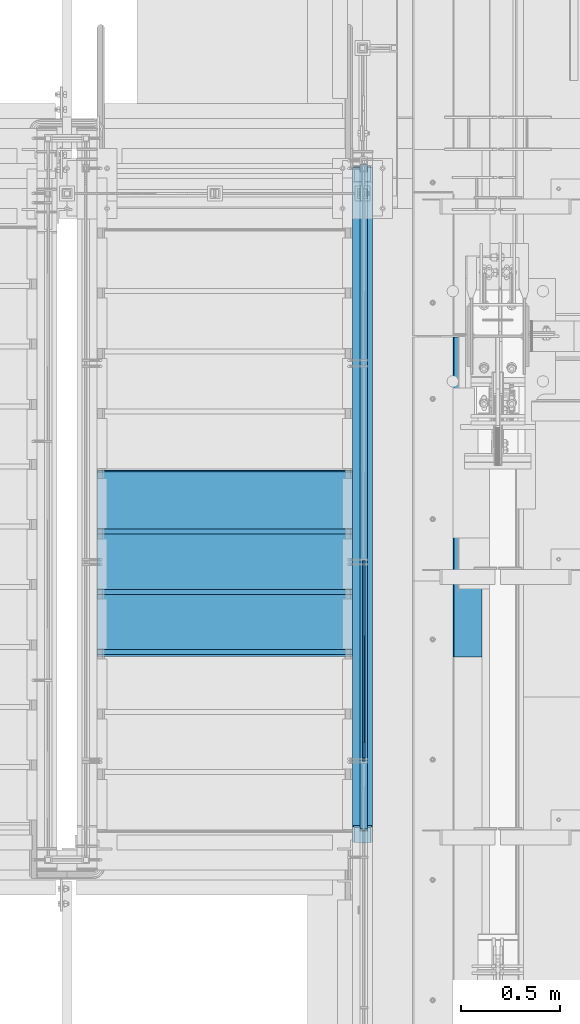
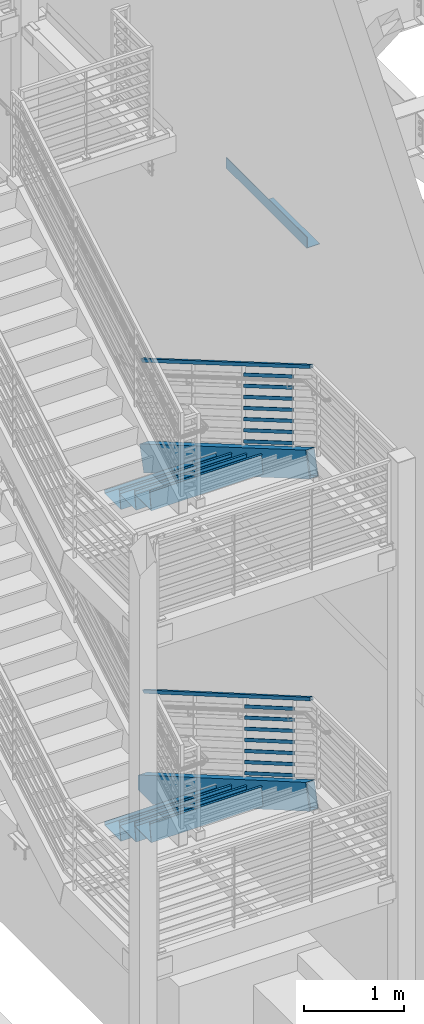
# One storey, part 761 of 1179: 18 members, 7 beams, 5 elements without a shape of their own.
"""IFC2X3 building model written with IfcOpenShell, lengths in millimetres."""

from ifc_helpers import new_model, si_unit, frame, origin_with_axes, place, context, subcontext, project, spatial, faceted_brep, material, type_object, element, aggregate, save


model = new_model("IFC2X3")

# Units and contexts
model_context = context("Model", 3, precision=1e-05, world=origin_with_axes())
body_context = subcontext(model_context, "Body", "Model", "MODEL_VIEW")
ifc_project = project(units=[si_unit("LENGTHUNIT", "METRE", prefix="MILLI"), si_unit("AREAUNIT", "SQUARE_METRE"), si_unit("VOLUMEUNIT", "CUBIC_METRE"), si_unit("MASSUNIT", "GRAM", prefix="KILO"), si_unit("TIMEUNIT", "SECOND"), si_unit("PLANEANGLEUNIT", "RADIAN"), si_unit("SOLIDANGLEUNIT", "STERADIAN"), si_unit("THERMODYNAMICTEMPERATUREUNIT", "DEGREE_CELSIUS"), si_unit("LUMINOUSINTENSITYUNIT", "LUMEN")], contexts=[model_context])

# Site, building, storey
site_placement = place(None, origin_with_axes())
site = spatial("IfcSite", under=ifc_project, at=site_placement, CompositionType="ELEMENT")
building_placement = place(site_placement, origin_with_axes())
building = spatial("IfcBuilding", under=site, at=building_placement, Name="Undefined", CompositionType="ELEMENT")
storey_placement = place(building_placement, origin_with_axes())
storey = spatial("IfcBuildingStorey", under=building, at=storey_placement, Name="Undefined", CompositionType="ELEMENT", Elevation=0.0)

# Assembly, members
assembly_1_placement = place(storey_placement, origin_with_axes())
assembly_1 = element("IfcElementAssembly", 1, at=assembly_1_placement, inside=storey, Name="GUARDRAIL", AssemblyPlace="NOTDEFINED", PredefinedType="RIGID_FRAME")
ifc_material_1 = material(Name="STEEL/A36")
member_type_1 = type_object("IfcMemberType", PredefinedType="NOTDEFINED")
member_1_placement = place(assembly_1_placement, frame((-247.650000724804, 33249.1605808903, 5514.93325604633), z_axis=(0.0, 0.503871025834968, 0.863778900717086), x_axis=(0.0, -0.863778900717086, 0.503871025834967)))
member_1 = element("IfcMember", 2, at=member_1_placement, type_object=member_type_1, material=ifc_material_1, Name="PLATE", context=body_context, shape_type="Brep", body=[
    faceted_brep([(-16.7114354625264, 4.76250000000005, -19.0500000000065), (5.51356370517169, 4.76250000000005, 19.0500000000338), (1164.83261782332, 4.76250000000005, 19.0499999989988), (1142.607617805, 4.76250000000005, -19.0500000010361), (5.51356370517169, -4.76250000000005, 19.0500000000338), (1164.83261782332, -4.76250000000005, 19.0499999989988), (-16.7114354625264, -4.76250000000005, -19.0500000000065), (1142.607617805, -4.76250000000005, -19.0500000010361)], [[[0, 1, 2, 3]], [[1, 4, 5, 2]], [[4, 6, 7, 5]], [[6, 0, 3, 7]], [[5, 7, 3, 2]], [[6, 4, 1, 0]]]),
])
member_2_placement = place(assembly_1_placement, frame((-247.650000724804, 33249.1605808862, 5651.11676564482), z_axis=(0.0, 0.503871025834968, 0.863778900717086), x_axis=(0.0, -0.863778900717086, 0.503871025834967)))
member_2 = element("IfcMember", 3, at=member_2_placement, type_object=member_type_1, material=ifc_material_1, Name="PLATE", context=body_context, shape_type="Brep", body=[
    faceted_brep([(-16.7114354625264, 4.76250000000005, -19.0500000000065), (5.51356370517169, 4.76250000000005, 19.0500000000338), (1164.83261782332, 4.76250000000005, 19.0499999989988), (1142.607617805, 4.76250000000005, -19.0500000010361), (5.51356370517169, -4.76250000000005, 19.0500000000338), (1164.83261782332, -4.76250000000005, 19.0499999989988), (-16.7114354625264, -4.76250000000005, -19.0500000000065), (1142.607617805, -4.76250000000005, -19.0500000010361)], [[[0, 1, 2, 3]], [[1, 4, 5, 2]], [[4, 6, 7, 5]], [[6, 0, 3, 7]], [[5, 7, 3, 2]], [[6, 4, 1, 0]]]),
])
member_3_placement = place(assembly_1_placement, frame((-247.650000724804, 33249.1605808819, 5787.30027524358), z_axis=(0.0, 0.503871025834968, 0.863778900717086), x_axis=(0.0, -0.863778900717086, 0.503871025834967)))
member_3 = element("IfcMember", 4, at=member_3_placement, type_object=member_type_1, material=ifc_material_1, Name="PLATE", context=body_context, shape_type="Brep", body=[
    faceted_brep([(-16.7114354625264, 4.76250000000005, -19.0500000000065), (5.51356370517169, 4.76250000000005, 19.0500000000338), (1164.83261782332, 4.76250000000005, 19.0499999989988), (1142.607617805, 4.76250000000005, -19.0500000010361), (5.51356370517169, -4.76250000000005, 19.0500000000338), (1164.83261782332, -4.76250000000005, 19.0499999989988), (-16.7114354625264, -4.76250000000005, -19.0500000000065), (1142.607617805, -4.76250000000005, -19.0500000010361)], [[[0, 1, 2, 3]], [[1, 4, 5, 2]], [[4, 6, 7, 5]], [[6, 0, 3, 7]], [[5, 7, 3, 2]], [[6, 4, 1, 0]]]),
])
member_4_placement = place(assembly_1_placement, frame((-247.650000724804, 33249.1605808778, 5923.48378484178), z_axis=(0.0, 0.503871025834968, 0.863778900717086), x_axis=(0.0, -0.863778900717086, 0.503871025834967)))
member_4 = element("IfcMember", 5, at=member_4_placement, type_object=member_type_1, material=ifc_material_1, Name="PLATE", context=body_context, shape_type="Brep", body=[
    faceted_brep([(-16.7114354625264, 4.76250000000005, -19.0500000000065), (5.51356370517169, 4.76250000000005, 19.0500000000338), (1164.83261782332, 4.76250000000005, 19.0499999989988), (1142.607617805, 4.76250000000005, -19.0500000010361), (5.51356370517169, -4.76250000000005, 19.0500000000338), (1164.83261782332, -4.76250000000005, 19.0499999989988), (-16.7114354625264, -4.76250000000005, -19.0500000000065), (1142.607617805, -4.76250000000005, -19.0500000010361)], [[[0, 1, 2, 3]], [[1, 4, 5, 2]], [[4, 6, 7, 5]], [[6, 0, 3, 7]], [[5, 7, 3, 2]], [[6, 4, 1, 0]]]),
])
member_5_placement = place(assembly_1_placement, frame((-247.650000724804, 33249.1605808735, 6059.66729443968), z_axis=(0.0, 0.503871025834968, 0.863778900717086), x_axis=(0.0, -0.863778900717086, 0.503871025834967)))
member_5 = element("IfcMember", 6, at=member_5_placement, type_object=member_type_1, material=ifc_material_1, Name="PLATE", context=body_context, shape_type="Brep", body=[
    faceted_brep([(-16.7114354625264, 4.76250000000005, -19.0500000000065), (5.51356370517169, 4.76250000000005, 19.0500000000338), (1164.83261782332, 4.76250000000005, 19.0499999989988), (1142.607617805, 4.76250000000005, -19.0500000010361), (5.51356370517169, -4.76250000000005, 19.0500000000338), (1164.83261782332, -4.76250000000005, 19.0499999989988), (-16.7114354625264, -4.76250000000005, -19.0500000000065), (1142.607617805, -4.76250000000005, -19.0500000010361)], [[[0, 1, 2, 3]], [[1, 4, 5, 2]], [[4, 6, 7, 5]], [[6, 0, 3, 7]], [[5, 7, 3, 2]], [[6, 4, 1, 0]]]),
])
member_6_placement = place(assembly_1_placement, frame((-247.650000724804, 33249.1605808693, 6195.85080403816), z_axis=(0.0, 0.503871025834968, 0.863778900717086), x_axis=(0.0, -0.863778900717086, 0.503871025834967)))
member_6 = element("IfcMember", 7, at=member_6_placement, type_object=member_type_1, material=ifc_material_1, Name="PLATE", context=body_context, shape_type="Brep", body=[
    faceted_brep([(-16.7114354625264, 4.76250000000005, -19.0500000000065), (5.51356370517169, 4.76250000000005, 19.0500000000338), (1164.83261782332, 4.76250000000005, 19.0499999989988), (1142.607617805, 4.76250000000005, -19.0500000010361), (5.51356370517169, -4.76250000000005, 19.0500000000338), (1164.83261782332, -4.76250000000005, 19.0499999989988), (-16.7114354625264, -4.76250000000005, -19.0500000000065), (1142.607617805, -4.76250000000005, -19.0500000010361)], [[[0, 1, 2, 3]], [[1, 4, 5, 2]], [[4, 6, 7, 5]], [[6, 0, 3, 7]], [[5, 7, 3, 2]], [[6, 4, 1, 0]]]),
])
member_7_placement = place(assembly_1_placement, frame((-247.650000724804, 33249.1605808927, 6332.03431414297), z_axis=(0.0, 0.503871025834968, 0.863778900717086), x_axis=(0.0, -0.863778900717086, 0.503871025834967)))
member_7 = element("IfcMember", 8, at=member_7_placement, type_object=member_type_1, material=ifc_material_1, Name="PLATE", context=body_context, shape_type="Brep", body=[
    faceted_brep([(-16.7114354625264, 4.76250000000005, -19.0500000000065), (5.51356370517169, 4.76250000000005, 19.0500000000338), (1164.83261782332, 4.76250000000005, 19.0499999989988), (1142.607617805, 4.76250000000005, -19.0500000010361), (5.51356370517169, -4.76250000000005, 19.0500000000338), (1164.83261782332, -4.76250000000005, 19.0499999989988), (-16.7114354625264, -4.76250000000005, -19.0500000000065), (1142.607617805, -4.76250000000005, -19.0500000010361)], [[[0, 1, 2, 3]], [[1, 4, 5, 2]], [[4, 6, 7, 5]], [[6, 0, 3, 7]], [[5, 7, 3, 2]], [[6, 4, 1, 0]]]),
])

assembly_2_placement = place(storey_placement, origin_with_axes())
assembly_2 = element("IfcElementAssembly", 9, at=assembly_2_placement, inside=storey, Name="GUARDRAIL", AssemblyPlace="NOTDEFINED", PredefinedType="RIGID_FRAME")
member_8_placement = place(assembly_2_placement, frame((-247.650000724804, 33226.354586849, 1461.11353197563), z_axis=(0.0, 0.501075923252298, 0.865403327435744), x_axis=(0.0, -0.865403327435743, 0.501075923252299)))
member_8 = element("IfcMember", 10, at=member_8_placement, type_object=member_type_1, material=ifc_material_1, Name="PLATE", context=body_context, shape_type="Brep", body=[
    faceted_brep([(-16.5570104603576, 4.76250000000005, -19.0500000000102), (5.50317738577724, 4.76250000000005, 19.0499999999902), (1153.84060725657, 4.76250000000005, 19.0499999998246), (1131.78038161306, 4.76250000000005, -19.0500000001994), (5.50317738577724, -4.76250000000005, 19.0499999999902), (1153.84060725657, -4.76250000000005, 19.0499999998246), (-16.5570104603576, -4.76250000000005, -19.0500000000102), (1131.78038161306, -4.76250000000005, -19.0500000001994)], [[[0, 1, 2, 3]], [[1, 4, 5, 2]], [[4, 6, 7, 5]], [[6, 0, 3, 7]], [[5, 7, 3, 2]], [[6, 4, 1, 0]]]),
])
member_9_placement = place(assembly_2_placement, frame((-247.650000724804, 33226.3545715452, 1597.21424660096), z_axis=(0.0, 0.501075923252298, 0.865403327435744), x_axis=(0.0, -0.865403327435743, 0.501075923252299)))
member_9 = element("IfcMember", 11, at=member_9_placement, type_object=member_type_1, material=ifc_material_1, Name="PLATE", context=body_context, shape_type="Brep", body=[
    faceted_brep([(-16.5570104603576, 4.76250000000005, -19.0500000000102), (5.50317738577724, 4.76250000000005, 19.0499999999902), (1153.84060725657, 4.76250000000005, 19.0499999998246), (1131.78038161306, 4.76250000000005, -19.0500000001994), (5.50317738577724, -4.76250000000005, 19.0499999999902), (1153.84060725657, -4.76250000000005, 19.0499999998246), (-16.5570104603576, -4.76250000000005, -19.0500000000102), (1131.78038161306, -4.76250000000005, -19.0500000001994)], [[[0, 1, 2, 3]], [[1, 4, 5, 2]], [[4, 6, 7, 5]], [[6, 0, 3, 7]], [[5, 7, 3, 2]], [[6, 4, 1, 0]]]),
])
member_10_placement = place(assembly_2_placement, frame((-247.650000724804, 33226.3545556691, 1733.31496122759), z_axis=(0.0, 0.501075923252298, 0.865403327435744), x_axis=(0.0, -0.865403327435743, 0.501075923252299)))
member_10 = element("IfcMember", 12, at=member_10_placement, type_object=member_type_1, material=ifc_material_1, Name="PLATE", context=body_context, shape_type="Brep", body=[
    faceted_brep([(-16.5570104603576, 4.76250000000005, -19.0500000000102), (5.50317738577724, 4.76250000000005, 19.0499999999902), (1153.84060725657, 4.76250000000005, 19.0499999998246), (1131.78038161306, 4.76250000000005, -19.0500000001994), (5.50317738577724, -4.76250000000005, 19.0499999999902), (1153.84060725657, -4.76250000000005, 19.0499999998246), (-16.5570104603576, -4.76250000000005, -19.0500000000102), (1131.78038161306, -4.76250000000005, -19.0500000001994)], [[[0, 1, 2, 3]], [[1, 4, 5, 2]], [[4, 6, 7, 5]], [[6, 0, 3, 7]], [[5, 7, 3, 2]], [[6, 4, 1, 0]]]),
])
member_11_placement = place(assembly_2_placement, frame((-247.650000724804, 33226.3545392012, 1869.41567590314), z_axis=(0.0, 0.501075923252298, 0.865403327435744), x_axis=(0.0, -0.865403327435743, 0.501075923252299)))
member_11 = element("IfcMember", 13, at=member_11_placement, type_object=member_type_1, material=ifc_material_1, Name="PLATE", context=body_context, shape_type="Brep", body=[
    faceted_brep([(-16.5570104603576, 4.76250000000005, -19.0500000000102), (5.50317738577724, 4.76250000000005, 19.0499999999902), (1153.84060725657, 4.76250000000005, 19.0499999998246), (1131.78038161306, 4.76250000000005, -19.0500000001994), (5.50317738577724, -4.76250000000005, 19.0499999999902), (1153.84060725657, -4.76250000000005, 19.0499999998246), (-16.5570104603576, -4.76250000000005, -19.0500000000102), (1131.78038161306, -4.76250000000005, -19.0500000001994)], [[[0, 1, 2, 3]], [[1, 4, 5, 2]], [[4, 6, 7, 5]], [[6, 0, 3, 7]], [[5, 7, 3, 2]], [[6, 4, 1, 0]]]),
])
member_12_placement = place(assembly_2_placement, frame((-247.650000724804, 33226.354522119, 2005.51639058164), z_axis=(0.0, 0.501075923252298, 0.865403327435744), x_axis=(0.0, -0.865403327435743, 0.501075923252299)))
member_12 = element("IfcMember", 14, at=member_12_placement, type_object=member_type_1, material=ifc_material_1, Name="PLATE", context=body_context, shape_type="Brep", body=[
    faceted_brep([(-16.5570104603576, 4.76250000000005, -19.0500000000102), (5.50317738577724, 4.76250000000005, 19.0499999999902), (1153.84060725657, 4.76250000000005, 19.0499999998246), (1131.78038161306, 4.76250000000005, -19.0500000001994), (5.50317738577724, -4.76250000000005, 19.0499999999902), (1153.84060725657, -4.76250000000005, 19.0499999998246), (-16.5570104603576, -4.76250000000005, -19.0500000000102), (1131.78038161306, -4.76250000000005, -19.0500000001994)], [[[0, 1, 2, 3]], [[1, 4, 5, 2]], [[4, 6, 7, 5]], [[6, 0, 3, 7]], [[5, 7, 3, 2]], [[6, 4, 1, 0]]]),
])
member_13_placement = place(assembly_2_placement, frame((-247.650000724804, 33226.354504398, 2141.61710525852), z_axis=(0.0, 0.501075923252298, 0.865403327435744), x_axis=(0.0, -0.865403327435743, 0.501075923252299)))
member_13 = element("IfcMember", 15, at=member_13_placement, type_object=member_type_1, material=ifc_material_1, Name="PLATE", context=body_context, shape_type="Brep", body=[
    faceted_brep([(-16.5570104603576, 4.76250000000005, -19.0500000000102), (5.50317738577724, 4.76250000000005, 19.0499999999902), (1153.84060725657, 4.76250000000005, 19.0499999998246), (1131.78038161306, 4.76250000000005, -19.0500000001994), (5.50317738577724, -4.76250000000005, 19.0499999999902), (1153.84060725657, -4.76250000000005, 19.0499999998246), (-16.5570104603576, -4.76250000000005, -19.0500000000102), (1131.78038161306, -4.76250000000005, -19.0500000001994)], [[[0, 1, 2, 3]], [[1, 4, 5, 2]], [[4, 6, 7, 5]], [[6, 0, 3, 7]], [[5, 7, 3, 2]], [[6, 4, 1, 0]]]),
])
member_14_placement = place(assembly_2_placement, frame((-247.650000724804, 33226.3545036904, 2277.71782039118), z_axis=(0.0, 0.501075923252298, 0.865403327435744), x_axis=(0.0, -0.865403327435743, 0.501075923252299)))
member_14 = element("IfcMember", 16, at=member_14_placement, type_object=member_type_1, material=ifc_material_1, Name="PLATE", context=body_context, shape_type="Brep", body=[
    faceted_brep([(-16.5570104603576, 4.76250000000005, -19.0500000000102), (5.50317738577724, 4.76250000000005, 19.0499999999902), (1153.84060725657, 4.76250000000005, 19.0499999998246), (1131.78038161306, 4.76250000000005, -19.0500000001994), (5.50317738577724, -4.76250000000005, 19.0499999999902), (1153.84060725657, -4.76250000000005, 19.0499999998246), (-16.5570104603576, -4.76250000000005, -19.0500000000102), (1131.78038161306, -4.76250000000005, -19.0500000001994)], [[[0, 1, 2, 3]], [[1, 4, 5, 2]], [[4, 6, 7, 5]], [[6, 0, 3, 7]], [[5, 7, 3, 2]], [[6, 4, 1, 0]]]),
])

# Member
ifc_material_2 = material()
member_type_2 = type_object("IfcMemberType", Name="HSS1-1/2X1-1/2X1/4", PredefinedType="NOTDEFINED")
member_15_placement = place(assembly_1_placement, frame((-247.650000744516, 35280.6000000218, 5280.02505193047), z_axis=(0.0, 0.503874729975411, 0.863776739957848), x_axis=(0.0, -0.863776739957847, 0.503874729975411)))
member_15 = element("IfcMember", 17, at=member_15_placement, type_object=member_type_2, material=ifc_material_2, Name="GUARDRAIL", ObjectType="HSS1-1/2X1-1/2X1/4", context=body_context, shape_type="Brep", body=[
    faceted_brep([(7.29446822322643, 12.69999933, -12.6999993300196), (7.29446822322643, -12.69999933, -12.6999993300196), (3922.19980143808, -12.69999933, -12.6999993361205), (3922.19980143808, 12.69999933, -12.6999993361205), (-7.29446591731903, -12.69999933, 12.6999993300342), (3929.05772221084, -12.69999933, 12.6999993239006), (-7.29446591731903, 12.69999933, 12.6999993300342), (3929.05772221084, 12.69999933, 12.6999993239006), (10.9417018962085, 19.049999235, -19.0499992350306), (-10.9416995903048, 19.049999235, 19.0499992350451), (3930.77220246883, 19.049999235, 19.0499992289006), (3920.48532118009, 19.049999235, -19.0499992411278), (-10.9416995903048, -19.049999235, 19.0499992350451), (3930.77220246883, -19.049999235, 19.0499992289006), (10.9417018962085, -19.049999235, -19.0499992350306), (3920.48532118009, -19.049999235, -19.0499992411278)], [[[0, 1, 2, 3]], [[1, 4, 5, 2]], [[4, 6, 7, 5]], [[6, 0, 3, 7]], [[8, 9, 10, 11]], [[9, 12, 13, 10]], [[12, 14, 15, 13]], [[14, 8, 11, 15]], [[13, 15, 11, 10], [5, 7, 3, 2]], [[14, 12, 9, 8], [6, 4, 1, 0]]]),
])

aggregate(assembly_1, [member_1, member_2, member_3, member_4, member_5, member_6, member_7, member_15])

member_16_placement = place(assembly_2_placement, frame((-247.650000744516, 35242.5000009842, 1243.27806163482), z_axis=(0.0, 0.501075923252298, 0.865403327435744), x_axis=(0.0, -0.865403327435743, 0.501075923252299)))
member_16 = element("IfcMember", 18, at=member_16_placement, type_object=member_type_2, material=ifc_material_2, Name="GUARDRAIL", ObjectType="HSS1-1/2X1-1/2X1/4", context=body_context, shape_type="Brep", body=[
    faceted_brep([(7.31623738029521, 12.69999933, -12.6999993299796), (7.31623738029521, -12.69999933, -12.6999993299796), (3870.85148213986, -12.69999933, -12.6999993233476), (3870.85148213986, 12.69999933, -12.6999993233476), (-7.31623738108465, -12.69999933, 12.6999993299796), (3877.67431101554, -12.69999933, 12.6999993366444), (-7.31623738108465, 12.69999933, 12.6999993299796), (3877.67431101554, 12.69999933, 12.6999993366444), (10.9743562088952, 19.049999235, -19.0499992349651), (-10.9743562096846, 19.049999235, 19.0499992349651), (3879.38001829893, 19.049999235, 19.0499992416444), (3869.14577485646, 19.049999235, -19.0499992283439), (-10.9743562096846, -19.049999235, 19.0499992349651), (3879.38001829893, -19.049999235, 19.0499992416444), (10.9743562088952, -19.049999235, -19.0499992349651), (3869.14577485646, -19.049999235, -19.0499992283439)], [[[0, 1, 2, 3]], [[1, 4, 5, 2]], [[4, 6, 7, 5]], [[6, 0, 3, 7]], [[8, 9, 10, 11]], [[9, 12, 13, 10]], [[12, 14, 15, 13]], [[14, 8, 11, 15]], [[13, 15, 11, 10], [5, 7, 3, 2]], [[14, 12, 9, 8], [6, 4, 1, 0]]]),
])

aggregate(assembly_2, [member_8, member_9, member_10, member_11, member_12, member_13, member_14, member_16])

# Assembly, beams
assembly_3_placement = place(storey_placement, origin_with_axes())
assembly_3 = element("IfcElementAssembly", 19, at=assembly_3_placement, inside=storey, Name="STRINGER", AssemblyPlace="NOTDEFINED", PredefinedType="RIGID_FRAME")
beam_type_1 = type_object("IfcBeamType", PredefinedType="NOTDEFINED")
beam_1_placement = place(assembly_3_placement, frame((-952.499999979676, 32778.7004612059, 1586.74473642806), z_axis=(-1.0, 0.0, 0.0), x_axis=(0.0, 1.0, 0.0)))
beam_1 = element("IfcBeam", 20, at=beam_1_placement, type_object=beam_type_1, material=ifc_material_1, Name="TREAD", context=body_context, shape_type="Brep", body=[
    faceted_brep([(-5.47515810467303e-10, -1.58750000000146, -647.7), (-5.47515810467303e-10, -1.58750000000146, 647.7), (5.49334799870849e-10, 1.58749999999418, 647.7), (5.49334799870849e-10, 1.58749999999418, -647.7), (21.7353257776667, 1.58750000000009, 647.7), (21.7353257776667, 1.58750000000009, -647.7), (25.4000000001688, -1.58750000000009, -647.7), (25.4000000001688, -1.58750000000009, 647.7), (-10.9760191413625, 228.869394137143, 647.7), (-10.9760191413625, 228.869394137143, -647.7), (-7.31134491886041, 225.694394137142, -647.7), (-7.31134491886041, 225.694394137142, 647.7), (319.224134592409, 228.869394137143, 647.7), (319.224134592409, 228.869394137143, -647.7), (316.473378484785, 225.694394137142, -647.7), (316.473378484785, 225.694394137142, 647.7), (325.043579912828, 188.435270791671, 647.7), (325.043579912828, 188.435270791671, -647.7), (321.900961419207, 187.982972213801, 647.7), (321.900961419207, 187.982972213801, -647.7)], [[[0, 1, 2, 3]], [[3, 2, 4, 5]], [[1, 0, 6, 7]], [[5, 4, 8, 9]], [[7, 6, 10, 11]], [[9, 8, 12, 13]], [[11, 10, 14, 15]], [[13, 12, 16, 17]], [[12, 8, 4, 2, 1, 7, 11, 15, 18, 16]], [[15, 14, 19, 18]], [[14, 10, 6, 0, 3, 5, 9, 13, 17, 19]], [[18, 19, 17, 16]]]),
])
beam_2_placement = place(assembly_3_placement, frame((-952.499999979636, 33083.5006149399, 1410.26284229092), z_axis=(-1.0, 0.0, 0.0), x_axis=(0.0, 1.0, 0.0)))
beam_2 = element("IfcBeam", 21, at=beam_2_placement, type_object=beam_type_1, material=ifc_material_1, Name="TREAD", context=body_context, shape_type="Brep", body=[
    faceted_brep([(-5.47515810467303e-10, -1.58750000000146, -647.7), (-5.47515810467303e-10, -1.58750000000146, 647.7), (5.49334799870849e-10, 1.58749999999418, 647.7), (5.49334799870849e-10, 1.58749999999418, -647.7), (21.7353257776667, 1.58750000000009, 647.7), (21.7353257776667, 1.58750000000009, -647.7), (25.4000000001688, -1.58750000000009, -647.7), (25.4000000001688, -1.58750000000009, 647.7), (-10.9760191413625, 228.869394137143, 647.7), (-10.9760191413625, 228.869394137143, -647.7), (-7.31134491886041, 225.694394137142, -647.7), (-7.31134491886041, 225.694394137142, 647.7), (319.224134592409, 228.869394137143, 647.7), (319.224134592409, 228.869394137143, -647.7), (316.473378484785, 225.694394137142, -647.7), (316.473378484785, 225.694394137142, 647.7), (325.043579912828, 188.435270791671, 647.7), (325.043579912828, 188.435270791671, -647.7), (321.900961419207, 187.982972213801, 647.7), (321.900961419207, 187.982972213801, -647.7)], [[[0, 1, 2, 3]], [[3, 2, 4, 5]], [[1, 0, 6, 7]], [[5, 4, 8, 9]], [[7, 6, 10, 11]], [[9, 8, 12, 13]], [[11, 10, 14, 15]], [[13, 12, 16, 17]], [[12, 8, 4, 2, 1, 7, 11, 15, 18, 16]], [[15, 14, 19, 18]], [[14, 10, 6, 0, 3, 5, 9, 13, 17, 19]], [[18, 19, 17, 16]]]),
])
beam_3_placement = place(assembly_3_placement, frame((-952.499999979596, 33388.300768674, 1233.78094815378), z_axis=(-1.0, 0.0, 0.0), x_axis=(0.0, 1.0, 0.0)))
beam_3 = element("IfcBeam", 22, at=beam_3_placement, type_object=beam_type_1, material=ifc_material_1, Name="TREAD", context=body_context, shape_type="Brep", body=[
    faceted_brep([(-5.47515810467303e-10, -1.58750000000146, -647.7), (-5.47515810467303e-10, -1.58750000000146, 647.7), (5.49334799870849e-10, 1.58749999999418, 647.7), (5.49334799870849e-10, 1.58749999999418, -647.7), (21.7353257776667, 1.58750000000009, 647.7), (21.7353257776667, 1.58750000000009, -647.7), (25.4000000001688, -1.58750000000009, -647.7), (25.4000000001688, -1.58750000000009, 647.7), (-10.9760191413625, 228.869394137143, 647.7), (-10.9760191413625, 228.869394137143, -647.7), (-7.31134491886041, 225.694394137142, -647.7), (-7.31134491886041, 225.694394137142, 647.7), (319.224134592409, 228.869394137143, 647.7), (319.224134592409, 228.869394137143, -647.7), (316.473378484785, 225.694394137142, -647.7), (316.473378484785, 225.694394137142, 647.7), (325.043579912828, 188.435270791671, 647.7), (325.043579912828, 188.435270791671, -647.7), (321.900961419207, 187.982972213801, 647.7), (321.900961419207, 187.982972213801, -647.7)], [[[0, 1, 2, 3]], [[3, 2, 4, 5]], [[1, 0, 6, 7]], [[5, 4, 8, 9]], [[7, 6, 10, 11]], [[9, 8, 12, 13]], [[11, 10, 14, 15]], [[13, 12, 16, 17]], [[12, 8, 4, 2, 1, 7, 11, 15, 18, 16]], [[15, 14, 19, 18]], [[14, 10, 6, 0, 3, 5, 9, 13, 17, 19]], [[18, 19, 17, 16]]]),
])

# Assembly, member
assembly_4_placement = place(storey_placement, origin_with_axes())
assembly_4 = element("IfcElementAssembly", 23, at=assembly_4_placement, inside=storey, Name="STRINGER", AssemblyPlace="NOTDEFINED", PredefinedType="RIGID_FRAME")
member_type_3 = type_object("IfcMemberType", Name="HSS12X4X3/8", PredefinedType="NOTDEFINED")
member_17_placement = place(assembly_4_placement, frame((-253.999999970508, 31826.6437920572, 6110.41009551645), z_axis=(0.0, 0.503871025834968, 0.863778900717086), x_axis=(0.0, 0.863778900717086, -0.503871025834967)))
member_17 = element("IfcMember", 24, at=member_17_placement, type_object=member_type_3, material=ifc_material_2, Name="STRINGER", ObjectType="HSS12X4X3/8", context=body_context, shape_type="Brep", body=[
    faceted_brep([(3954.08431987612, 50.8000000000002, -152.399999996698), (3871.68190144677, 50.8000000000002, 152.400000003652), (3872.0238482502, 50.4699036320367, 152.400000003649), (3884.03468255634, 41.2750000000001, 143.205096371612), (3961.46543237346, 41.2750000000001, -143.20509636464), (3954.42626667955, 50.4699036320367, -152.399999996698), (3961.46543237346, -41.2750000000001, -143.20509636464), (3954.42626667955, -50.4699036320367, -152.399999996698), (3872.0238482502, -50.4699036320367, 152.400000003649), (3884.03468255634, -41.2750000000001, 143.205096371612), (3871.68190144677, -50.8000000000002, 152.400000003652), (3954.08431987612, -50.8000000000002, -152.399999996698), (79.916584105973, 41.2750000000001, -143.205096368083), (91.927418412095, 50.4699036320367, -152.400000000127), (91.927418412095, -50.4699036320367, -152.400000000127), (79.916584105973, -41.2750000000001, -143.205096368083), (2.4858342888474, 41.2750000000001, 143.205096368167), (9.52499998274288, 50.4699036320367, 152.400000000223), (9.86694677204468, 50.8000000000029, 152.39999999994), (92.2693648904242, 50.8000000000029, -152.399999999852), (2.4858342888474, -41.2750000000001, 143.205096368167), (9.52499998274288, -50.4699036320367, 152.400000000223), (92.2693648904242, -50.8000000000029, -152.399999996655), (9.86694677204105, -50.8000000000029, 152.400000000649), (79.827342666882, 41.2750000000015, -142.875), (79.827342666882, -41.2750000000015, -142.875), (3961.37619110366, -41.2750000000001, -142.87499999668), (3961.37619110366, 41.2750000000001, -142.87499999668), (2.57507555327538, -41.2750000000015, 142.875), (3884.12392382614, -41.2750000000001, 142.875000003649), (2.57507555327538, 41.2750000000015, 142.875), (3884.12392382614, 41.2750000000001, 142.875000003649)], [[[0, 1, 2, 3, 4, 5]], [[6, 7, 5, 4]], [[3, 2, 8, 9]], [[9, 8, 10, 11, 7, 6]], [[12, 13, 14, 15]], [[16, 17, 18, 19, 13, 12]], [[17, 16, 20, 21]], [[22, 23, 21, 20, 15, 14]], [[24, 25, 26, 27]], [[25, 28, 29, 26]], [[28, 30, 31, 29]], [[30, 24, 27, 31]], [[19, 18, 1, 0]], [[2, 1, 18, 17, 21, 23, 10, 8]], [[23, 22, 11, 10]], [[11, 22, 14, 13, 19, 0, 5, 7]], [[3, 9, 6, 4], [29, 31, 27, 26]], [[16, 12, 15, 20], [30, 28, 25, 24]]]),
])

# Member
member_18_placement = place(assembly_3_placement, frame((-253.999999998505, 31826.9816878739, 2036.69045173536), z_axis=(0.0, 0.501075923252298, 0.865403327435744), x_axis=(0.0, 0.865403327435743, -0.501075923252299)))
member_18 = element("IfcMember", 25, at=member_18_placement, type_object=member_type_3, material=ifc_material_2, Name="STRINGER", ObjectType="HSS12X4X3/8", context=body_context, shape_type="Brep", body=[
    faceted_brep([(91.3989514037676, -50.4739097931884, -152.400000000103), (79.4029832500382, -41.275, -143.201090206909), (79.4029832500382, 41.275, -143.201090206909), (91.3989514037676, 50.4739097931885, -152.400000000103), (91.7366011133199, -50.8, -152.400000000103), (9.86264972250137, -50.8, 152.400000000118), (9.52500001294902, -50.4739097931884, 152.400000000122), (2.47096816667181, -41.275, 143.20109020692), (9.52500001294902, 50.4739097931884, 152.400000000122), (2.47096816667181, 41.275, 143.20109020692), (9.86264972250137, 50.8, 152.400000000118), (91.7366011133199, 50.8, -152.400000000103), (3911.70449924685, -41.275, 142.875000000742), (3895.18301415309, -50.8, 152.400000000747), (3987.74575316547, -50.8, -7.46420144078365), (4000.76147828138, -41.275, -10.9344376741574), (3772.88822322913, 41.275, -142.874999999498), (3737.42859598844, 50.8, -152.399999999514), (3987.74576341834, 50.8, -7.46421914945313), (4000.76147828138, 41.275, -10.9344376741574), (3895.18301415309, 50.8, 152.400000000747), (3911.70449924685, 41.275, 142.875000000742), (3737.42859598844, -50.8, -152.399999999514), (3772.88822322913, -41.275, -142.874999999498), (2.5585604918524, -41.2750000000001, 142.875), (2.5585604918524, 41.2750000000001, 142.875), (79.3153899732097, -41.2750000000001, -142.875), (79.3153899732097, 41.2750000000001, -142.875)], [[[0, 1, 2, 3]], [[4, 5, 6, 7, 1, 0]], [[8, 9, 7, 6]], [[9, 8, 10, 11, 3, 2]], [[12, 13, 14, 15]], [[16, 17, 18, 19]], [[20, 21, 19, 18]], [[22, 23, 15, 14]], [[23, 22, 17, 16]], [[24, 25, 21, 12]], [[23, 26, 24, 12, 15]], [[27, 26, 23, 16]], [[7, 9, 2, 1], [25, 24, 26, 27]], [[13, 20, 10, 8, 6, 5]], [[21, 20, 13, 12]], [[25, 27, 16, 19, 21]], [[20, 18, 17, 11, 10]], [[11, 17, 22, 4, 0, 3]], [[22, 14, 13, 5, 4]]]),
])

aggregate(assembly_3, [member_18, beam_1, beam_2, beam_3])

# Beam
beam_type_2 = type_object("IfcBeamType", PredefinedType="NOTDEFINED")
beam_4_placement = place(assembly_4_placement, frame((-952.499999977583, 32778.6999998333, 5656.2624996694), z_axis=(-1.0, 0.0, 0.0), x_axis=(0.0, 1.0, 0.0)))
beam_4 = element("IfcBeam", 26, at=beam_4_placement, type_object=beam_type_2, material=ifc_material_1, Name="TREAD", context=body_context, shape_type="Brep", body=[
    faceted_brep([(-5.47515810467303e-10, -1.58750000000146, -647.7), (-5.47515810467303e-10, -1.58750000000146, 647.7), (5.49334799870849e-10, 1.58749999999418, 647.7), (5.49334799870849e-10, 1.58749999999418, -647.7), (21.7391942417962, 1.58749999999964, 647.7), (21.7391942417962, 1.58749999999964, -647.7), (25.4000000001688, -1.58750000000009, -647.7), (25.4000000001688, -1.58750000000009, 647.7), (-10.9179486153444, 230.1875, 647.7), (-10.9179486153444, 230.1875, -647.7), (-7.25714285782306, 227.012500000001, -647.7), (-7.25714285782306, 227.012500000001, 647.7), (319.2820511338, 230.1875, 647.7), (319.2820511338, 230.1875, -647.7), (316.528388233419, 227.012500000001, -647.7), (316.528388233419, 227.012500000001, 647.7), (325.059631548502, 189.744437097058, 647.7), (325.059631548502, 189.744437097058, -647.7), (321.916541906132, 189.295424291005, 647.7), (321.916541906132, 189.295424291005, -647.7)], [[[0, 1, 2, 3]], [[3, 2, 4, 5]], [[1, 0, 6, 7]], [[5, 4, 8, 9]], [[7, 6, 10, 11]], [[9, 8, 12, 13]], [[11, 10, 14, 15]], [[13, 12, 16, 17]], [[12, 8, 4, 2, 1, 7, 11, 15, 18, 16]], [[15, 14, 19, 18]], [[14, 10, 6, 0, 3, 5, 9, 13, 17, 19]], [[18, 19, 17, 16]]]),
])

beam_5_placement = place(assembly_4_placement, frame((-952.499999982262, 33083.4999997693, 5478.46249956029), z_axis=(-1.0, 0.0, 0.0), x_axis=(0.0, 1.0, 0.0)))
beam_5 = element("IfcBeam", 27, at=beam_5_placement, type_object=beam_type_2, material=ifc_material_1, Name="TREAD", context=body_context, shape_type="Brep", body=[
    faceted_brep([(-5.47515810467303e-10, -1.58750000000146, -647.7), (-5.47515810467303e-10, -1.58750000000146, 647.7), (5.49334799870849e-10, 1.58749999999418, 647.7), (5.49334799870849e-10, 1.58749999999418, -647.7), (21.7391942417962, 1.58749999999964, 647.7), (21.7391942417962, 1.58749999999964, -647.7), (25.4000000001688, -1.58750000000009, -647.7), (25.4000000001688, -1.58750000000009, 647.7), (-10.9179486153444, 230.1875, 647.7), (-10.9179486153444, 230.1875, -647.7), (-7.25714285782306, 227.012500000001, -647.7), (-7.25714285782306, 227.012500000001, 647.7), (319.2820511338, 230.1875, 647.7), (319.2820511338, 230.1875, -647.7), (316.528388233419, 227.012500000001, -647.7), (316.528388233419, 227.012500000001, 647.7), (325.059631548502, 189.744437097058, 647.7), (325.059631548502, 189.744437097058, -647.7), (321.916541906132, 189.295424291005, 647.7), (321.916541906132, 189.295424291005, -647.7)], [[[0, 1, 2, 3]], [[3, 2, 4, 5]], [[1, 0, 6, 7]], [[5, 4, 8, 9]], [[7, 6, 10, 11]], [[9, 8, 12, 13]], [[11, 10, 14, 15]], [[13, 12, 16, 17]], [[12, 8, 4, 2, 1, 7, 11, 15, 18, 16]], [[15, 14, 19, 18]], [[14, 10, 6, 0, 3, 5, 9, 13, 17, 19]], [[18, 19, 17, 16]]]),
])

beam_6_placement = place(assembly_4_placement, frame((-952.49999998694, 33388.2999997053, 5300.66249945), z_axis=(-1.0, 0.0, 0.0), x_axis=(0.0, 1.0, 0.0)))
beam_6 = element("IfcBeam", 28, at=beam_6_placement, type_object=beam_type_2, material=ifc_material_1, Name="TREAD", context=body_context, shape_type="Brep", body=[
    faceted_brep([(-5.47515810467303e-10, -1.58750000000146, -647.7), (-5.47515810467303e-10, -1.58750000000146, 647.7), (5.49334799870849e-10, 1.58749999999418, 647.7), (5.49334799870849e-10, 1.58749999999418, -647.7), (21.7391942417962, 1.58749999999964, 647.7), (21.7391942417962, 1.58749999999964, -647.7), (25.4000000001688, -1.58750000000009, -647.7), (25.4000000001688, -1.58750000000009, 647.7), (-10.9179486153444, 230.1875, 647.7), (-10.9179486153444, 230.1875, -647.7), (-7.25714285782306, 227.012500000001, -647.7), (-7.25714285782306, 227.012500000001, 647.7), (319.2820511338, 230.1875, 647.7), (319.2820511338, 230.1875, -647.7), (316.528388233419, 227.012500000001, -647.7), (316.528388233419, 227.012500000001, 647.7), (325.059631548502, 189.744437097058, 647.7), (325.059631548502, 189.744437097058, -647.7), (321.916541906132, 189.295424291005, 647.7), (321.916541906132, 189.295424291005, -647.7)], [[[0, 1, 2, 3]], [[3, 2, 4, 5]], [[1, 0, 6, 7]], [[5, 4, 8, 9]], [[7, 6, 10, 11]], [[9, 8, 12, 13]], [[11, 10, 14, 15]], [[13, 12, 16, 17]], [[12, 8, 4, 2, 1, 7, 11, 15, 18, 16]], [[15, 14, 19, 18]], [[14, 10, 6, 0, 3, 5, 9, 13, 17, 19]], [[18, 19, 17, 16]]]),
])

aggregate(assembly_4, [member_17, beam_4, beam_5, beam_6])

# Assembly, beam
assembly_5_placement = place(storey_placement, origin_with_axes())
assembly_5 = element("IfcElementAssembly", 29, at=assembly_5_placement, inside=storey, Name="BEAM", AssemblyPlace="NOTDEFINED", PredefinedType="RIGID_FRAME")
beam_type_3 = type_object("IfcBeamType", PredefinedType="NOTDEFINED")
beam_7_placement = place(assembly_5_placement, frame((352.425013608027, 33577.2124997437, 8016.875), z_axis=(0.0, 1.0, 0.0), x_axis=(-1.0, 0.0, 0.0)))
beam_7 = element("IfcBeam", 30, at=beam_7_placement, type_object=beam_type_3, material=ifc_material_1, Name="BENT_PLATE", context=body_context, shape_type="Brep", body=[
    faceted_brep([(84.137515620022, -3.1749999915819, 122.853291810738), (84.137515359672, 3.17500000841846, 122.853291810738), (-3.72040176443988e-10, 3.17499999999927, 122.853291829117), (2.63412403000984e-10, -3.175000000002, 122.853291829117), (84.137515622332, -3.1749999915819, 811.212499981724), (84.137515361982, 3.17500000841846, 811.212500000103), (149.22499992491, -3.17499998506901, -811.212499999809), (6.76607214700198e-10, -3.175000000002, -811.212500000005), (4.1154635255225e-11, 3.17499999999927, -811.212500000005), (142.874999664567, 3.17500001429653, -811.21249999982), (142.874994457342, 130.175012039234, -811.212499999758), (149.224994457342, 130.175012299576, -811.212499999747), (142.874999663078, 3.17500001429653, 811.212500000183), (142.874994456573, 130.17501203845, 811.212500000242), (149.224994456573, 130.175012298793, 811.212500000256), (149.224999923421, -3.17499998506901, 811.212500000191)], [[[0, 1, 2, 3]], [[4, 5, 1, 0]], [[6, 7, 8, 9, 10, 11]], [[9, 12, 13, 10]], [[14, 11, 10, 13]], [[15, 6, 11, 14]], [[3, 7, 6, 15, 4, 0]], [[8, 7, 3, 2]], [[12, 9, 8, 2, 1, 5]], [[15, 14, 13, 12, 5, 4]]]),
])
aggregate(assembly_5, [beam_7])

save(model, "model.ifc")
